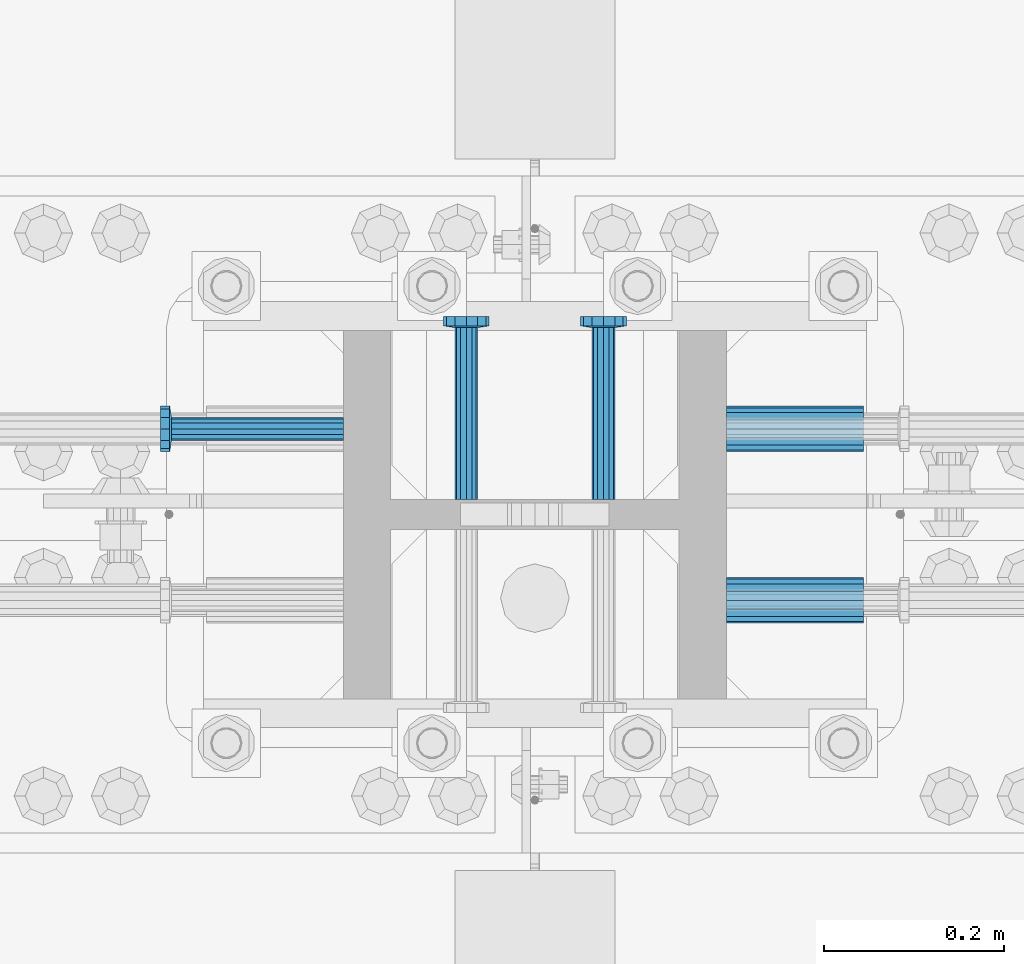
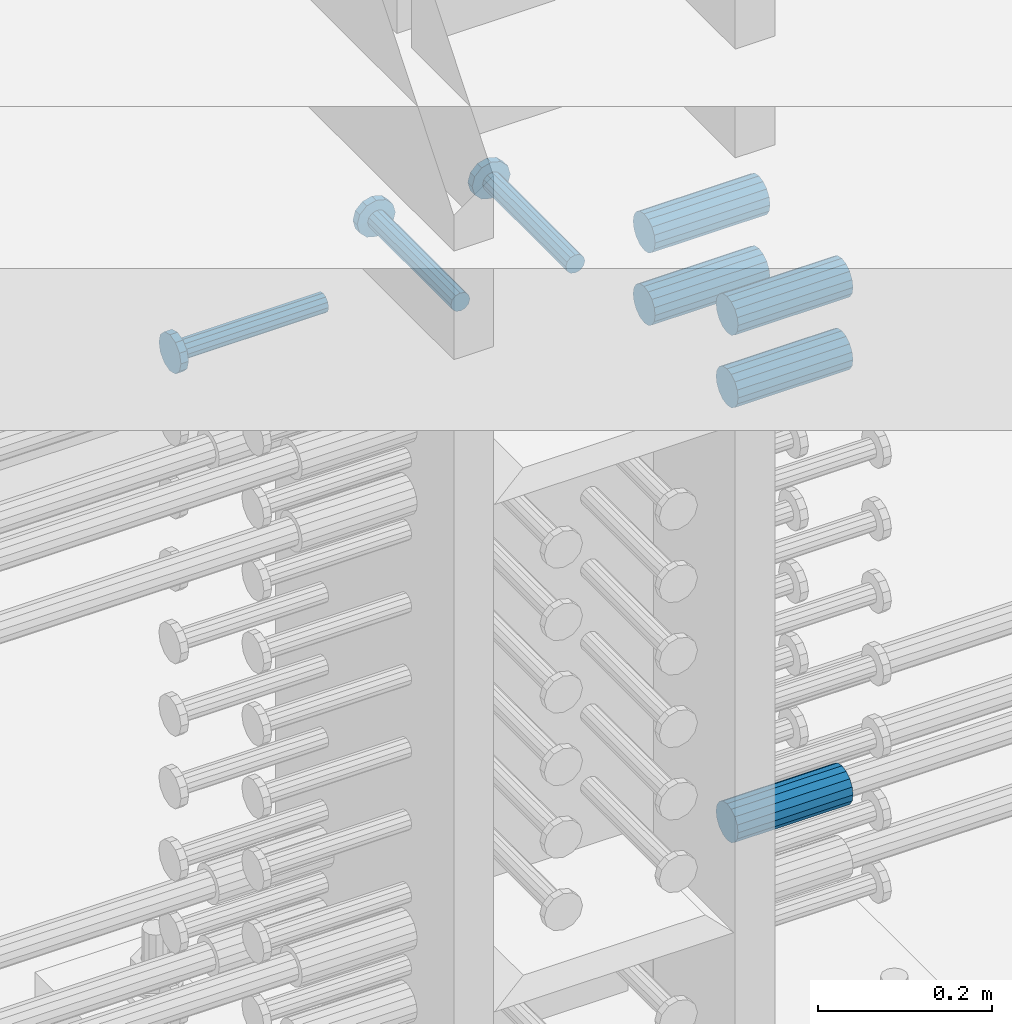
# One storey, part 1215 of 1763: 8 beams, 1 element without a shape of its own.
"""IFC2X3 building model written with IfcOpenShell, lengths in millimetres."""

from ifc_helpers import new_model, si_unit, frame, origin_with_axes, place, context, subcontext, project, spatial, faceted_brep, material, type_object, element, aggregate, save


model = new_model("IFC2X3")

# Units and contexts
model_context = context("Model", 3, precision=1e-05, world=origin_with_axes())
body_context = subcontext(model_context, "Body", "Model", "MODEL_VIEW")
ifc_project = project(units=[si_unit("LENGTHUNIT", "METRE", prefix="MILLI"), si_unit("AREAUNIT", "SQUARE_METRE"), si_unit("VOLUMEUNIT", "CUBIC_METRE"), si_unit("MASSUNIT", "GRAM", prefix="KILO"), si_unit("TIMEUNIT", "SECOND"), si_unit("PLANEANGLEUNIT", "RADIAN"), si_unit("SOLIDANGLEUNIT", "STERADIAN"), si_unit("THERMODYNAMICTEMPERATUREUNIT", "DEGREE_CELSIUS"), si_unit("LUMINOUSINTENSITYUNIT", "LUMEN")], contexts=[model_context])

# Site, building, storey
site_placement = place(None, origin_with_axes())
site = spatial("IfcSite", under=ifc_project, at=site_placement, CompositionType="ELEMENT")
building_placement = place(site_placement, origin_with_axes())
building = spatial("IfcBuilding", under=site, at=building_placement, Name="Undefined", CompositionType="ELEMENT")
storey_placement = place(building_placement, origin_with_axes())
storey = spatial("IfcBuildingStorey", under=building, at=storey_placement, Name="Undefined", CompositionType="ELEMENT", Elevation=0.0)

# Assembly, beams
assembly_placement = place(storey_placement, origin_with_axes())
assembly = element("IfcElementAssembly", 1, at=assembly_placement, inside=storey, Name="COLUMN", AssemblyPlace="NOTDEFINED", PredefinedType="RIGID_FRAME")
ifc_material_1 = material(Name="STEEL/A706-GR.80")
beam_type_1 = type_object("IfcBeamType", PredefinedType="NOTDEFINED")
beam_1_placement = place(assembly_placement, frame((-61381.712286658, 361.950000000006, 4165.60000000003), z_axis=(0.0, 0.0, 1.0), x_axis=(1.0, 0.0, 0.0)))
beam_1 = element("IfcBeam", 2, at=beam_1_placement, type_object=beam_type_1, material=ifc_material_1, Name="HALF COUPLER F", context=body_context, shape_type="Brep", body=[
    faceted_brep([(32.7659999999996, -8.95349999999962, -15.507916905568), (32.7659999999996, 0.0, -17.9070000000002), (32.7659999999996, 8.95349999999962, -15.507916905568), (32.7659999999996, 15.507916905568, -8.95350000000008), (32.7659999999996, 17.9069999999992, 0.0), (32.7659999999996, 15.507916905568, 8.95350000000008), (32.7659999999996, 8.95349999999962, 15.507916905568), (32.7659999999996, 0.0, 17.9070000000002), (32.7659999999996, -8.95349999999962, 15.507916905568), (32.7659999999996, -15.507916905568, 8.95350000000008), (32.7659999999996, -17.9069999999992, 0.0), (32.7659999999996, -15.507916905568, -8.95350000000008), (152.400103102711, -15.507916905568, 8.95350000000008), (152.400103102711, -8.95349999999962, 15.507916905568), (152.400103102711, -17.9069999999992, 0.0), (152.400103102711, -15.507916905568, -8.95350000000008), (152.400103102711, -8.95349999999962, -15.507916905568), (152.400103102711, 0.0, -17.9070000000002), (152.400103102711, 8.95349999999962, -15.507916905568), (152.400103102711, 15.507916905568, -8.95350000000008), (152.400103102711, 17.9069999999992, 0.0), (152.400103102711, 15.507916905568, 8.95350000000008), (152.400103102711, 8.95349999999962, 15.507916905568), (152.400103102711, 0.0, 17.9070000000002), (0.0, -23.466540125788, 9.72015918207308), (0.0, -17.9605122421381, 17.9605122421385), (0.0, -9.72015918207398, 23.4665401257867), (0.0, 0.0, 25.4000000000001), (0.0, 9.72015918207398, 23.4665401257867), (0.0, 17.9605122421381, 17.9605122421385), (0.0, 23.466540125788, 9.72015918207308), (0.0, 25.4000000000015, 0.0), (0.0, 23.466540125788, -9.72015918207308), (0.0, 17.9605122421381, -17.9605122421385), (0.0, 9.72015918207398, -23.4665401257867), (0.0, 0.0, -25.4000000000001), (0.0, -9.72015918207398, -23.4665401257867), (0.0, -17.9605122421381, -17.9605122421385), (0.0, -23.466540125788, -9.72015918207308), (0.0, -25.4000000000015, 0.0), (152.400103102711, -25.4000000000015, 0.0), (152.400103102711, -23.466540125788, 9.72015918207308), (152.400103102711, -17.9605122421381, 17.9605122421385), (152.400103102711, -9.72015918207398, 23.4665401257867), (152.400103102711, 0.0, 25.4000000000001), (152.400103102711, 9.72015918207398, 23.4665401257867), (152.400103102711, 17.9605122421381, 17.9605122421385), (152.400103102711, 23.466540125788, 9.72015918207308), (152.400103102711, 25.4000000000015, 0.0), (152.400103102711, 23.466540125788, -9.72015918207308), (152.400103102711, 17.9605122421381, -17.9605122421385), (152.400103102711, 9.72015918207398, -23.4665401257867), (152.400103102711, 0.0, -25.4000000000001), (152.400103102711, -9.72015918207398, -23.4665401257867), (152.400103102711, -17.9605122421381, -17.9605122421385), (152.400103102711, -23.466540125788, -9.72015918207308)], [[[0, 1, 2, 3, 4, 5, 6, 7, 8, 9, 10, 11]], [[12, 9, 8, 13]], [[14, 10, 9, 12]], [[15, 11, 10, 14]], [[16, 0, 11, 15]], [[17, 1, 0, 16]], [[18, 2, 1, 17]], [[19, 3, 2, 18]], [[20, 4, 3, 19]], [[21, 5, 4, 20]], [[22, 6, 5, 21]], [[23, 7, 6, 22]], [[13, 8, 7, 23]], [[24, 25, 26, 27, 28, 29, 30, 31, 32, 33, 34, 35, 36, 37, 38, 39]], [[24, 39, 40, 41]], [[25, 24, 41, 42]], [[26, 25, 42, 43]], [[27, 26, 43, 44]], [[28, 27, 44, 45]], [[29, 28, 45, 46]], [[30, 29, 46, 47]], [[31, 30, 47, 48]], [[32, 31, 48, 49]], [[33, 32, 49, 50]], [[34, 33, 50, 51]], [[35, 34, 51, 52]], [[36, 35, 52, 53]], [[37, 36, 53, 54]], [[38, 37, 54, 55]], [[39, 38, 55, 40]], [[54, 53, 52, 51, 50, 49, 48, 47, 46, 45, 44, 43, 42, 41, 40, 55], [21, 20, 19, 18, 17, 16, 15, 14, 12, 13, 23, 22]]]),
])
beam_2_placement = place(assembly_placement, frame((-61381.7122867317, 552.449999999419, 4775.20000000009), z_axis=(0.0, 0.0, 1.0), x_axis=(1.0, 0.0, 0.0)))
beam_2 = element("IfcBeam", 3, at=beam_2_placement, type_object=beam_type_1, material=ifc_material_1, Name="HALF COUPLER F", context=body_context, shape_type="Brep", body=[
    faceted_brep([(0.0, -23.466540125788, 9.72015918207308), (0.0, -17.9605122421381, 17.9605122421385), (0.0, -9.72015918207398, 23.4665401257867), (0.0, 0.0, 25.4000000000001), (0.0, 9.72015918207398, 23.4665401257867), (0.0, 17.9605122421381, 17.9605122421385), (0.0, 23.466540125788, 9.72015918207308), (0.0, 25.4000000000015, 0.0), (0.0, 23.466540125788, -9.72015918207308), (0.0, 17.9605122421381, -17.9605122421385), (0.0, 9.72015918207398, -23.4665401257867), (0.0, 0.0, -25.4000000000001), (0.0, -9.72015918207398, -23.4665401257867), (0.0, -17.9605122421381, -17.9605122421385), (0.0, -23.466540125788, -9.72015918207308), (0.0, -25.4000000000015, 0.0), (152.400103102711, -25.4000000000015, 0.0), (152.400103102711, -23.466540125788, 9.72015918207308), (152.400103102711, -17.9605122421381, 17.9605122421385), (152.400103102711, -9.72015918207398, 23.4665401257867), (152.400103102711, 0.0, 25.4000000000001), (152.400103102711, 9.72015918207398, 23.4665401257867), (152.400103102711, 17.9605122421381, 17.9605122421385), (152.400103102711, 23.466540125788, 9.72015918207308), (152.400103102711, 25.4000000000015, 0.0), (152.400103102711, 23.466540125788, -9.72015918207308), (152.400103102711, 17.9605122421381, -17.9605122421385), (152.400103102711, 9.72015918207398, -23.4665401257867), (152.400103102711, 0.0, -25.4000000000001), (152.400103102711, -9.72015918207398, -23.4665401257867), (152.400103102711, -17.9605122421381, -17.9605122421385), (152.400103102711, -23.466540125788, -9.72015918207308), (152.400103102711, 15.507916905568, 8.95350000000008), (152.400103102711, 17.9069999999992, 0.0), (152.400103102711, 15.507916905568, -8.95350000000008), (152.400103102711, 8.95349999999962, -15.507916905568), (152.400103102711, 0.0, -17.9070000000002), (152.400103102711, -8.95349999999962, -15.507916905568), (152.400103102711, -15.507916905568, -8.95350000000008), (152.400103102711, -17.9069999999992, 0.0), (152.400103102711, -15.507916905568, 8.95350000000008), (152.400103102711, -8.95349999999962, 15.507916905568), (152.400103102711, 0.0, 17.9070000000002), (152.400103102711, 8.95349999999962, 15.507916905568), (32.7659999999996, -8.95349999999962, -15.507916905568), (32.7659999999996, -15.507916905568, -8.95350000000008), (32.7659999999996, 0.0, -17.9070000000002), (32.7659999999996, 8.95349999999962, -15.507916905568), (32.7659999999996, 15.507916905568, -8.95350000000008), (32.7659999999996, 17.9069999999992, 0.0), (32.7659999999996, 15.507916905568, 8.95350000000008), (32.7659999999996, 8.95349999999962, 15.507916905568), (32.7659999999996, 0.0, 17.9070000000002), (32.7659999999996, -8.95349999999962, 15.507916905568), (32.7659999999996, -15.507916905568, 8.95350000000008), (32.7659999999996, -17.9069999999992, 0.0)], [[[0, 1, 2, 3, 4, 5, 6, 7, 8, 9, 10, 11, 12, 13, 14, 15]], [[0, 15, 16, 17]], [[1, 0, 17, 18]], [[2, 1, 18, 19]], [[3, 2, 19, 20]], [[4, 3, 20, 21]], [[5, 4, 21, 22]], [[6, 5, 22, 23]], [[7, 6, 23, 24]], [[8, 7, 24, 25]], [[9, 8, 25, 26]], [[10, 9, 26, 27]], [[11, 10, 27, 28]], [[12, 11, 28, 29]], [[13, 12, 29, 30]], [[14, 13, 30, 31]], [[15, 14, 31, 16]], [[30, 29, 28, 27, 26, 25, 24, 23, 22, 21, 20, 19, 18, 17, 16, 31], [32, 33, 34, 35, 36, 37, 38, 39, 40, 41, 42, 43]], [[37, 44, 45, 38]], [[36, 46, 44, 37]], [[35, 47, 46, 36]], [[34, 48, 47, 35]], [[33, 49, 48, 34]], [[32, 50, 49, 33]], [[43, 51, 50, 32]], [[42, 52, 51, 43]], [[41, 53, 52, 42]], [[40, 54, 53, 41]], [[39, 55, 54, 40]], [[38, 45, 55, 39]], [[44, 46, 47, 48, 49, 50, 51, 52, 53, 54, 55, 45]]]),
])
beam_3_placement = place(assembly_placement, frame((-61381.7123553935, 361.950000000006, 4775.20000000009), z_axis=(0.0, 0.0, 1.0), x_axis=(1.0, 0.0, 0.0)))
beam_3 = element("IfcBeam", 4, at=beam_3_placement, type_object=beam_type_1, material=ifc_material_1, Name="HALF COUPLER F", context=body_context, shape_type="Brep", body=[
    faceted_brep([(32.7659999999996, -8.95349999999962, -15.507916905568), (32.7659999999996, 0.0, -17.9070000000002), (32.7659999999996, 8.95349999999962, -15.507916905568), (32.7659999999996, 15.507916905568, -8.95350000000008), (32.7659999999996, 17.9069999999992, 0.0), (32.7659999999996, 15.507916905568, 8.95350000000008), (32.7659999999996, 8.95349999999962, 15.507916905568), (32.7659999999996, 0.0, 17.9070000000002), (32.7659999999996, -8.95349999999962, 15.507916905568), (32.7659999999996, -15.507916905568, 8.95350000000008), (32.7659999999996, -17.9069999999992, 0.0), (32.7659999999996, -15.507916905568, -8.95350000000008), (152.400103102711, -15.507916905568, 8.95350000000008), (152.400103102711, -8.95349999999962, 15.507916905568), (152.400103102711, -17.9069999999992, 0.0), (152.400103102711, -15.507916905568, -8.95350000000008), (152.400103102711, -8.95349999999962, -15.507916905568), (152.400103102711, 0.0, -17.9070000000002), (152.400103102711, 8.95349999999962, -15.507916905568), (152.400103102711, 15.507916905568, -8.95350000000008), (152.400103102711, 17.9069999999992, 0.0), (152.400103102711, 15.507916905568, 8.95350000000008), (152.400103102711, 8.95349999999962, 15.507916905568), (152.400103102711, 0.0, 17.9070000000002), (0.0, -23.466540125788, 9.72015918207308), (0.0, -17.9605122421381, 17.9605122421385), (0.0, -9.72015918207398, 23.4665401257867), (0.0, 0.0, 25.4000000000001), (0.0, 9.72015918207398, 23.4665401257867), (0.0, 17.9605122421381, 17.9605122421385), (0.0, 23.466540125788, 9.72015918207308), (0.0, 25.4000000000015, 0.0), (0.0, 23.466540125788, -9.72015918207308), (0.0, 17.9605122421381, -17.9605122421385), (0.0, 9.72015918207398, -23.4665401257867), (0.0, 0.0, -25.4000000000001), (0.0, -9.72015918207398, -23.4665401257867), (0.0, -17.9605122421381, -17.9605122421385), (0.0, -23.466540125788, -9.72015918207308), (0.0, -25.4000000000015, 0.0), (152.400103102711, -25.4000000000015, 0.0), (152.400103102711, -23.466540125788, 9.72015918207308), (152.400103102711, -17.9605122421381, 17.9605122421385), (152.400103102711, -9.72015918207398, 23.4665401257867), (152.400103102711, 0.0, 25.4000000000001), (152.400103102711, 9.72015918207398, 23.4665401257867), (152.400103102711, 17.9605122421381, 17.9605122421385), (152.400103102711, 23.466540125788, 9.72015918207308), (152.400103102711, 25.4000000000015, 0.0), (152.400103102711, 23.466540125788, -9.72015918207308), (152.400103102711, 17.9605122421381, -17.9605122421385), (152.400103102711, 9.72015918207398, -23.4665401257867), (152.400103102711, 0.0, -25.4000000000001), (152.400103102711, -9.72015918207398, -23.4665401257867), (152.400103102711, -17.9605122421381, -17.9605122421385), (152.400103102711, -23.466540125788, -9.72015918207308)], [[[0, 1, 2, 3, 4, 5, 6, 7, 8, 9, 10, 11]], [[12, 9, 8, 13]], [[14, 10, 9, 12]], [[15, 11, 10, 14]], [[16, 0, 11, 15]], [[17, 1, 0, 16]], [[18, 2, 1, 17]], [[19, 3, 2, 18]], [[20, 4, 3, 19]], [[21, 5, 4, 20]], [[22, 6, 5, 21]], [[23, 7, 6, 22]], [[13, 8, 7, 23]], [[24, 25, 26, 27, 28, 29, 30, 31, 32, 33, 34, 35, 36, 37, 38, 39]], [[24, 39, 40, 41]], [[25, 24, 41, 42]], [[26, 25, 42, 43]], [[27, 26, 43, 44]], [[28, 27, 44, 45]], [[29, 28, 45, 46]], [[30, 29, 46, 47]], [[31, 30, 47, 48]], [[32, 31, 48, 49]], [[33, 32, 49, 50]], [[34, 33, 50, 51]], [[35, 34, 51, 52]], [[36, 35, 52, 53]], [[37, 36, 53, 54]], [[38, 37, 54, 55]], [[39, 38, 55, 40]], [[54, 53, 52, 51, 50, 49, 48, 47, 46, 45, 44, 43, 42, 41, 40, 55], [21, 20, 19, 18, 17, 16, 15, 14, 12, 13, 23, 22]]]),
])
beam_4_placement = place(assembly_placement, frame((-61381.7122867317, 552.449999999419, 4876.80000000009), z_axis=(0.0, 0.0, 1.0), x_axis=(1.0, 0.0, 0.0)))
beam_4 = element("IfcBeam", 5, at=beam_4_placement, type_object=beam_type_1, material=ifc_material_1, Name="HALF COUPLER F", context=body_context, shape_type="Brep", body=[
    faceted_brep([(0.0, -23.466540125788, 9.72015918207308), (0.0, -17.9605122421381, 17.9605122421385), (0.0, -9.72015918207398, 23.4665401257867), (0.0, 0.0, 25.4000000000001), (0.0, 9.72015918207398, 23.4665401257867), (0.0, 17.9605122421381, 17.9605122421385), (0.0, 23.466540125788, 9.72015918207308), (0.0, 25.4000000000015, 0.0), (0.0, 23.466540125788, -9.72015918207308), (0.0, 17.9605122421381, -17.9605122421385), (0.0, 9.72015918207398, -23.4665401257867), (0.0, 0.0, -25.4000000000001), (0.0, -9.72015918207398, -23.4665401257867), (0.0, -17.9605122421381, -17.9605122421385), (0.0, -23.466540125788, -9.72015918207308), (0.0, -25.4000000000015, 0.0), (152.400103102711, -25.4000000000015, 0.0), (152.400103102711, -23.466540125788, 9.72015918207308), (152.400103102711, -17.9605122421381, 17.9605122421385), (152.400103102711, -9.72015918207398, 23.4665401257867), (152.400103102711, 0.0, 25.4000000000001), (152.400103102711, 9.72015918207398, 23.4665401257867), (152.400103102711, 17.9605122421381, 17.9605122421385), (152.400103102711, 23.466540125788, 9.72015918207308), (152.400103102711, 25.4000000000015, 0.0), (152.400103102711, 23.466540125788, -9.72015918207308), (152.400103102711, 17.9605122421381, -17.9605122421385), (152.400103102711, 9.72015918207398, -23.4665401257867), (152.400103102711, 0.0, -25.4000000000001), (152.400103102711, -9.72015918207398, -23.4665401257867), (152.400103102711, -17.9605122421381, -17.9605122421385), (152.400103102711, -23.466540125788, -9.72015918207308), (152.400103102711, 15.507916905568, 8.95350000000008), (152.400103102711, 17.9069999999992, 0.0), (152.400103102711, 15.507916905568, -8.95350000000008), (152.400103102711, 8.95349999999962, -15.507916905568), (152.400103102711, 0.0, -17.9070000000002), (152.400103102711, -8.95349999999962, -15.507916905568), (152.400103102711, -15.507916905568, -8.95350000000008), (152.400103102711, -17.9069999999992, 0.0), (152.400103102711, -15.507916905568, 8.95350000000008), (152.400103102711, -8.95349999999962, 15.507916905568), (152.400103102711, 0.0, 17.9070000000002), (152.400103102711, 8.95349999999962, 15.507916905568), (32.7659999999996, -8.95349999999962, -15.507916905568), (32.7659999999996, -15.507916905568, -8.95350000000008), (32.7659999999996, 0.0, -17.9070000000002), (32.7659999999996, 8.95349999999962, -15.507916905568), (32.7659999999996, 15.507916905568, -8.95350000000008), (32.7659999999996, 17.9069999999992, 0.0), (32.7659999999996, 15.507916905568, 8.95350000000008), (32.7659999999996, 8.95349999999962, 15.507916905568), (32.7659999999996, 0.0, 17.9070000000002), (32.7659999999996, -8.95349999999962, 15.507916905568), (32.7659999999996, -15.507916905568, 8.95350000000008), (32.7659999999996, -17.9069999999992, 0.0)], [[[0, 1, 2, 3, 4, 5, 6, 7, 8, 9, 10, 11, 12, 13, 14, 15]], [[0, 15, 16, 17]], [[1, 0, 17, 18]], [[2, 1, 18, 19]], [[3, 2, 19, 20]], [[4, 3, 20, 21]], [[5, 4, 21, 22]], [[6, 5, 22, 23]], [[7, 6, 23, 24]], [[8, 7, 24, 25]], [[9, 8, 25, 26]], [[10, 9, 26, 27]], [[11, 10, 27, 28]], [[12, 11, 28, 29]], [[13, 12, 29, 30]], [[14, 13, 30, 31]], [[15, 14, 31, 16]], [[30, 29, 28, 27, 26, 25, 24, 23, 22, 21, 20, 19, 18, 17, 16, 31], [32, 33, 34, 35, 36, 37, 38, 39, 40, 41, 42, 43]], [[37, 44, 45, 38]], [[36, 46, 44, 37]], [[35, 47, 46, 36]], [[34, 48, 47, 35]], [[33, 49, 48, 34]], [[32, 50, 49, 33]], [[43, 51, 50, 32]], [[42, 52, 51, 43]], [[41, 53, 52, 42]], [[40, 54, 53, 41]], [[39, 55, 54, 40]], [[38, 45, 55, 39]], [[44, 46, 47, 48, 49, 50, 51, 52, 53, 54, 55, 45]]]),
])
beam_5_placement = place(assembly_placement, frame((-61381.7123553935, 361.950000000006, 4876.80000000009), z_axis=(0.0, 0.0, 1.0), x_axis=(1.0, 0.0, 0.0)))
beam_5 = element("IfcBeam", 6, at=beam_5_placement, type_object=beam_type_1, material=ifc_material_1, Name="HALF COUPLER F", context=body_context, shape_type="Brep", body=[
    faceted_brep([(32.7659999999996, -8.95349999999962, -15.507916905568), (32.7659999999996, 0.0, -17.9070000000002), (32.7659999999996, 8.95349999999962, -15.507916905568), (32.7659999999996, 15.507916905568, -8.95350000000008), (32.7659999999996, 17.9069999999992, 0.0), (32.7659999999996, 15.507916905568, 8.95350000000008), (32.7659999999996, 8.95349999999962, 15.507916905568), (32.7659999999996, 0.0, 17.9070000000002), (32.7659999999996, -8.95349999999962, 15.507916905568), (32.7659999999996, -15.507916905568, 8.95350000000008), (32.7659999999996, -17.9069999999992, 0.0), (32.7659999999996, -15.507916905568, -8.95350000000008), (152.400103102711, -15.507916905568, 8.95350000000008), (152.400103102711, -8.95349999999962, 15.507916905568), (152.400103102711, -17.9069999999992, 0.0), (152.400103102711, -15.507916905568, -8.95350000000008), (152.400103102711, -8.95349999999962, -15.507916905568), (152.400103102711, 0.0, -17.9070000000002), (152.400103102711, 8.95349999999962, -15.507916905568), (152.400103102711, 15.507916905568, -8.95350000000008), (152.400103102711, 17.9069999999992, 0.0), (152.400103102711, 15.507916905568, 8.95350000000008), (152.400103102711, 8.95349999999962, 15.507916905568), (152.400103102711, 0.0, 17.9070000000002), (0.0, -23.466540125788, 9.72015918207308), (0.0, -17.9605122421381, 17.9605122421385), (0.0, -9.72015918207398, 23.4665401257867), (0.0, 0.0, 25.4000000000001), (0.0, 9.72015918207398, 23.4665401257867), (0.0, 17.9605122421381, 17.9605122421385), (0.0, 23.466540125788, 9.72015918207308), (0.0, 25.4000000000015, 0.0), (0.0, 23.466540125788, -9.72015918207308), (0.0, 17.9605122421381, -17.9605122421385), (0.0, 9.72015918207398, -23.4665401257867), (0.0, 0.0, -25.4000000000001), (0.0, -9.72015918207398, -23.4665401257867), (0.0, -17.9605122421381, -17.9605122421385), (0.0, -23.466540125788, -9.72015918207308), (0.0, -25.4000000000015, 0.0), (152.400103102711, -25.4000000000015, 0.0), (152.400103102711, -23.466540125788, 9.72015918207308), (152.400103102711, -17.9605122421381, 17.9605122421385), (152.400103102711, -9.72015918207398, 23.4665401257867), (152.400103102711, 0.0, 25.4000000000001), (152.400103102711, 9.72015918207398, 23.4665401257867), (152.400103102711, 17.9605122421381, 17.9605122421385), (152.400103102711, 23.466540125788, 9.72015918207308), (152.400103102711, 25.4000000000015, 0.0), (152.400103102711, 23.466540125788, -9.72015918207308), (152.400103102711, 17.9605122421381, -17.9605122421385), (152.400103102711, 9.72015918207398, -23.4665401257867), (152.400103102711, 0.0, -25.4000000000001), (152.400103102711, -9.72015918207398, -23.4665401257867), (152.400103102711, -17.9605122421381, -17.9605122421385), (152.400103102711, -23.466540125788, -9.72015918207308)], [[[0, 1, 2, 3, 4, 5, 6, 7, 8, 9, 10, 11]], [[12, 9, 8, 13]], [[14, 10, 9, 12]], [[15, 11, 10, 14]], [[16, 0, 11, 15]], [[17, 1, 0, 16]], [[18, 2, 1, 17]], [[19, 3, 2, 18]], [[20, 4, 3, 19]], [[21, 5, 4, 20]], [[22, 6, 5, 21]], [[23, 7, 6, 22]], [[13, 8, 7, 23]], [[24, 25, 26, 27, 28, 29, 30, 31, 32, 33, 34, 35, 36, 37, 38, 39]], [[24, 39, 40, 41]], [[25, 24, 41, 42]], [[26, 25, 42, 43]], [[27, 26, 43, 44]], [[28, 27, 44, 45]], [[29, 28, 45, 46]], [[30, 29, 46, 47]], [[31, 30, 47, 48]], [[32, 31, 48, 49]], [[33, 32, 49, 50]], [[34, 33, 50, 51]], [[35, 34, 51, 52]], [[36, 35, 52, 53]], [[37, 36, 53, 54]], [[38, 37, 54, 55]], [[39, 38, 55, 40]], [[54, 53, 52, 51, 50, 49, 48, 47, 46, 45, 44, 43, 42, 41, 40, 55], [21, 20, 19, 18, 17, 16, 15, 14, 12, 13, 23, 22]]]),
])
ifc_material_2 = material(Name="STEEL/A108")
beam_type_2 = type_object("IfcBeamType", PredefinedType="NOTDEFINED")
beam_6_placement = place(assembly_placement, frame((-61518.2374118359, 473.869000000006, 4927.60000000008), z_axis=(1.0, 0.0, 0.0), x_axis=(0.0, 1.0, 0.0)))
beam_6 = element("IfcBeam", 7, at=beam_6_placement, type_object=beam_type_2, material=ifc_material_2, Name="HEADED STUD ANCHOR", context=body_context, shape_type="Brep", body=[
    faceted_brep([(0.0, -12.6999999999971, -1.81898940354586e-12), (3.63797880709171e-12, -11.0, -6.34999990463257), (191.00799999576, -11.0, -6.34999990454889), (191.007999995752, -12.6999998092651, 8.36735125631094e-11), (7.27595761418343e-12, -6.34999990463257, -11.0), (191.00799999576, -6.34999990463257, -10.9999999999163), (3.63797880709171e-12, 0.0, -12.6999998092651), (191.00799999576, 0.0, -12.6999998091815), (7.27595761418343e-12, 6.34999990463257, -11.0), (191.00799999576, 6.34999990463257, -10.9999999999163), (3.63797880709171e-12, 11.0, -6.34999990463257), (191.00799999576, 11.0, -6.34999990454889), (0.0, 12.6999999999971, -1.81898940354586e-12), (191.007999995752, 12.6999998092651, 8.36735125631094e-11), (0.0, 11.0, 6.34999990463257), (191.007999995752, 11.0, 6.34999990471624), (-3.63797880709171e-12, 6.34999990463257, 11.0), (191.007999995749, 6.34999990463257, 11.0000000000837), (-3.63797880709171e-12, 0.0, 12.6999998092651), (191.007999995749, 0.0, 12.6999998093488), (-3.63797880709171e-12, -6.34999990463257, 11.0), (191.007999995749, -6.34999990463257, 11.0000000000837), (0.0, -11.0, 6.34999990463257), (191.007999995752, -11.0, 6.34999990471624), (193.039999995715, -22.0, -12.6999998091796), (193.039999995708, -25.3999996185303, 8.54925019666553e-11), (193.039999995719, -12.6999998092651, -21.9999999999145), (193.039999995719, 0.0, -25.3999996184448), (193.039999995719, 12.6999998092651, -21.9999999999145), (193.039999995715, 22.0, -12.6999998091796), (193.039999995708, 25.3999996185303, 8.54925019666553e-11), (193.039999995704, 22.0, 12.6999998093506), (193.039999995701, 12.6999998092651, 22.0000000000855), (193.039999995697, 0.0, 25.3999996186158), (193.039999995701, -12.6999998092651, 22.0000000000855), (193.039999995704, -22.0, 12.6999998093506), (203.199999995486, -22.0, -12.6999998091742), (203.199999995482, -25.3999996185303, 9.09494701772928e-11), (203.199999995493, -12.6999998092651, -21.9999999999091), (203.199999995493, 0.0, -25.3999996184393), (203.199999995493, 12.6999998092651, -21.9999999999091), (203.199999995486, 22.0, -12.6999998091742), (203.199999995482, 25.3999996185303, 9.09494701772928e-11), (203.199999995479, 22.0, 12.6999998093561), (203.199999995475, 12.6999998092651, 22.0000000000909), (203.199999995471, 0.0, 25.3999996186212), (203.199999995475, -12.6999998092651, 22.0000000000909), (203.199999995479, -22.0, 12.6999998093561)], [[[0, 1, 2, 3]], [[1, 4, 5, 2]], [[4, 6, 7, 5]], [[6, 8, 9, 7]], [[8, 10, 11, 9]], [[10, 12, 13, 11]], [[12, 14, 15, 13]], [[14, 16, 17, 15]], [[16, 18, 19, 17]], [[18, 20, 21, 19]], [[20, 22, 23, 21]], [[22, 0, 3, 23]], [[22, 20, 18, 16, 14, 12, 10, 8, 6, 4, 1, 0]], [[3, 2, 24, 25]], [[2, 5, 26, 24]], [[5, 7, 27, 26]], [[7, 9, 28, 27]], [[9, 11, 29, 28]], [[11, 13, 30, 29]], [[13, 15, 31, 30]], [[15, 17, 32, 31]], [[17, 19, 33, 32]], [[19, 21, 34, 33]], [[21, 23, 35, 34]], [[23, 3, 25, 35]], [[25, 24, 36, 37]], [[24, 26, 38, 36]], [[26, 27, 39, 38]], [[27, 28, 40, 39]], [[28, 29, 41, 40]], [[29, 30, 42, 41]], [[30, 31, 43, 42]], [[31, 32, 44, 43]], [[32, 33, 45, 44]], [[33, 34, 46, 45]], [[34, 35, 47, 46]], [[35, 25, 37, 47]], [[38, 39, 40, 41, 42, 43, 44, 45, 46, 47, 37, 36]]]),
])
beam_7_placement = place(assembly_placement, frame((-61670.6374118357, 473.868999002865, 4927.60000000008), z_axis=(1.0, 0.0, 0.0), x_axis=(0.0, 1.0, 0.0)))
beam_7 = element("IfcBeam", 8, at=beam_7_placement, type_object=beam_type_2, material=ifc_material_2, Name="HEADED STUD ANCHOR", context=body_context, shape_type="Brep", body=[
    faceted_brep([(0.0, -12.6999999999971, -1.81898940354586e-12), (3.63797880709171e-12, -11.0, -6.34999990463257), (191.00799999576, -11.0, -6.34999990454889), (191.007999995752, -12.6999998092651, 8.36735125631094e-11), (7.27595761418343e-12, -6.34999990463257, -11.0), (191.00799999576, -6.34999990463257, -10.9999999999163), (3.63797880709171e-12, 0.0, -12.6999998092651), (191.00799999576, 0.0, -12.6999998091815), (7.27595761418343e-12, 6.34999990463257, -11.0), (191.00799999576, 6.34999990463257, -10.9999999999163), (3.63797880709171e-12, 11.0, -6.34999990463257), (191.00799999576, 11.0, -6.34999990454889), (0.0, 12.6999999999971, -1.81898940354586e-12), (191.007999995752, 12.6999998092651, 8.36735125631094e-11), (0.0, 11.0, 6.34999990463257), (191.007999995752, 11.0, 6.34999990471624), (-3.63797880709171e-12, 6.34999990463257, 11.0), (191.007999995749, 6.34999990463257, 11.0000000000837), (-3.63797880709171e-12, 0.0, 12.6999998092651), (191.007999995749, 0.0, 12.6999998093488), (-3.63797880709171e-12, -6.34999990463257, 11.0), (191.007999995749, -6.34999990463257, 11.0000000000837), (0.0, -11.0, 6.34999990463257), (191.007999995752, -11.0, 6.34999990471624), (193.039999995715, -22.0, -12.6999998091796), (193.039999995708, -25.3999996185303, 8.54925019666553e-11), (193.039999995719, -12.6999998092651, -21.9999999999145), (193.039999995719, 0.0, -25.3999996184448), (193.039999995719, 12.6999998092651, -21.9999999999145), (193.039999995715, 22.0, -12.6999998091796), (193.039999995708, 25.3999996185303, 8.54925019666553e-11), (193.039999995704, 22.0, 12.6999998093506), (193.039999995701, 12.6999998092651, 22.0000000000855), (193.039999995697, 0.0, 25.3999996186158), (193.039999995701, -12.6999998092651, 22.0000000000855), (193.039999995704, -22.0, 12.6999998093506), (203.199999995486, -22.0, -12.6999998091742), (203.199999995482, -25.3999996185303, 9.09494701772928e-11), (203.199999995493, -12.6999998092651, -21.9999999999091), (203.199999995493, 0.0, -25.3999996184393), (203.199999995493, 12.6999998092651, -21.9999999999091), (203.199999995486, 22.0, -12.6999998091742), (203.199999995482, 25.3999996185303, 9.09494701772928e-11), (203.199999995479, 22.0, 12.6999998093561), (203.199999995475, 12.6999998092651, 22.0000000000909), (203.199999995471, 0.0, 25.3999996186212), (203.199999995475, -12.6999998092651, 22.0000000000909), (203.199999995479, -22.0, 12.6999998093561)], [[[0, 1, 2, 3]], [[1, 4, 5, 2]], [[4, 6, 7, 5]], [[6, 8, 9, 7]], [[8, 10, 11, 9]], [[10, 12, 13, 11]], [[12, 14, 15, 13]], [[14, 16, 17, 15]], [[16, 18, 19, 17]], [[18, 20, 21, 19]], [[20, 22, 23, 21]], [[22, 0, 3, 23]], [[22, 20, 18, 16, 14, 12, 10, 8, 6, 4, 1, 0]], [[3, 2, 24, 25]], [[2, 5, 26, 24]], [[5, 7, 27, 26]], [[7, 9, 28, 27]], [[9, 11, 29, 28]], [[11, 13, 30, 29]], [[13, 15, 31, 30]], [[15, 17, 32, 31]], [[17, 19, 33, 32]], [[19, 21, 34, 33]], [[21, 23, 35, 34]], [[23, 3, 25, 35]], [[25, 24, 36, 37]], [[24, 26, 38, 36]], [[26, 27, 39, 38]], [[27, 28, 40, 39]], [[28, 29, 41, 40]], [[29, 30, 42, 41]], [[30, 31, 43, 42]], [[31, 32, 44, 43]], [[32, 33, 45, 44]], [[33, 34, 46, 45]], [[34, 35, 47, 46]], [[35, 25, 37, 47]], [[38, 39, 40, 41, 42, 43, 44, 45, 46, 47, 37, 36]]]),
])
beam_8_placement = place(assembly_placement, frame((-61807.1622736986, 552.449999999823, 4927.60000000008), z_axis=(0.0, 1.0, 0.0), x_axis=(-1.0, 0.0, 0.0)))
beam_8 = element("IfcBeam", 9, at=beam_8_placement, type_object=beam_type_2, material=ifc_material_2, Name="HEADED STUD ANCHOR", context=body_context, shape_type="Brep", body=[
    faceted_brep([(0.0, -12.6999999999971, -1.81898940354586e-12), (3.63797880709171e-12, -11.0, -6.34999990463257), (191.00799999576, -11.0, -6.34999990454889), (191.007999995752, -12.6999998092651, 8.36735125631094e-11), (7.27595761418343e-12, -6.34999990463257, -11.0), (191.00799999576, -6.34999990463257, -10.9999999999163), (3.63797880709171e-12, 0.0, -12.6999998092651), (191.00799999576, 0.0, -12.6999998091815), (7.27595761418343e-12, 6.34999990463257, -11.0), (191.00799999576, 6.34999990463257, -10.9999999999163), (3.63797880709171e-12, 11.0, -6.34999990463257), (191.00799999576, 11.0, -6.34999990454889), (0.0, 12.6999999999971, -1.81898940354586e-12), (191.007999995752, 12.6999998092651, 8.36735125631094e-11), (0.0, 11.0, 6.34999990463257), (191.007999995752, 11.0, 6.34999990471624), (-3.63797880709171e-12, 6.34999990463257, 11.0), (191.007999995749, 6.34999990463257, 11.0000000000837), (-3.63797880709171e-12, 0.0, 12.6999998092651), (191.007999995749, 0.0, 12.6999998093488), (-3.63797880709171e-12, -6.34999990463257, 11.0), (191.007999995749, -6.34999990463257, 11.0000000000837), (0.0, -11.0, 6.34999990463257), (191.007999995752, -11.0, 6.34999990471624), (193.039999995715, -22.0, -12.6999998091796), (193.039999995708, -25.3999996185303, 8.54925019666553e-11), (193.039999995719, -12.6999998092651, -21.9999999999145), (193.039999995719, 0.0, -25.3999996184448), (193.039999995719, 12.6999998092651, -21.9999999999145), (193.039999995715, 22.0, -12.6999998091796), (193.039999995708, 25.3999996185303, 8.54925019666553e-11), (193.039999995704, 22.0, 12.6999998093506), (193.039999995701, 12.6999998092651, 22.0000000000855), (193.039999995697, 0.0, 25.3999996186158), (193.039999995701, -12.6999998092651, 22.0000000000855), (193.039999995704, -22.0, 12.6999998093506), (203.199999995486, -22.0, -12.6999998091742), (203.199999995482, -25.3999996185303, 9.09494701772928e-11), (203.199999995493, -12.6999998092651, -21.9999999999091), (203.199999995493, 0.0, -25.3999996184393), (203.199999995493, 12.6999998092651, -21.9999999999091), (203.199999995486, 22.0, -12.6999998091742), (203.199999995482, 25.3999996185303, 9.09494701772928e-11), (203.199999995479, 22.0, 12.6999998093561), (203.199999995475, 12.6999998092651, 22.0000000000909), (203.199999995471, 0.0, 25.3999996186212), (203.199999995475, -12.6999998092651, 22.0000000000909), (203.199999995479, -22.0, 12.6999998093561)], [[[0, 1, 2, 3]], [[1, 4, 5, 2]], [[4, 6, 7, 5]], [[6, 8, 9, 7]], [[8, 10, 11, 9]], [[10, 12, 13, 11]], [[12, 14, 15, 13]], [[14, 16, 17, 15]], [[16, 18, 19, 17]], [[18, 20, 21, 19]], [[20, 22, 23, 21]], [[22, 0, 3, 23]], [[22, 20, 18, 16, 14, 12, 10, 8, 6, 4, 1, 0]], [[3, 2, 24, 25]], [[2, 5, 26, 24]], [[5, 7, 27, 26]], [[7, 9, 28, 27]], [[9, 11, 29, 28]], [[11, 13, 30, 29]], [[13, 15, 31, 30]], [[15, 17, 32, 31]], [[17, 19, 33, 32]], [[19, 21, 34, 33]], [[21, 23, 35, 34]], [[23, 3, 25, 35]], [[25, 24, 36, 37]], [[24, 26, 38, 36]], [[26, 27, 39, 38]], [[27, 28, 40, 39]], [[28, 29, 41, 40]], [[29, 30, 42, 41]], [[30, 31, 43, 42]], [[31, 32, 44, 43]], [[32, 33, 45, 44]], [[33, 34, 46, 45]], [[34, 35, 47, 46]], [[35, 25, 37, 47]], [[38, 39, 40, 41, 42, 43, 44, 45, 46, 47, 37, 36]]]),
])
aggregate(assembly, [beam_1, beam_2, beam_3, beam_4, beam_5, beam_6, beam_7, beam_8])

save(model, "model.ifc")
